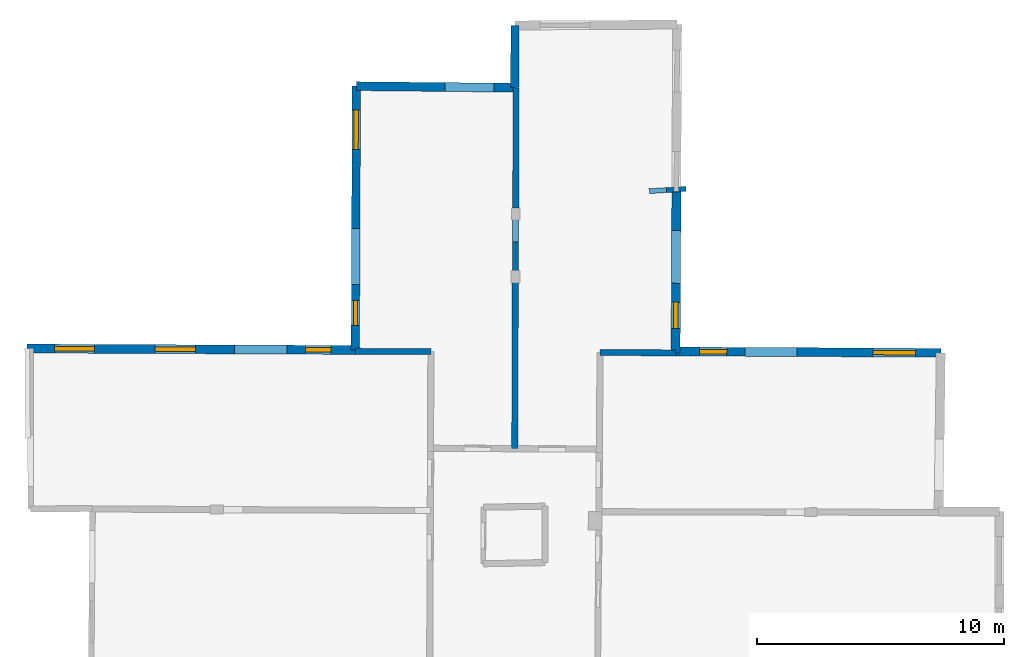
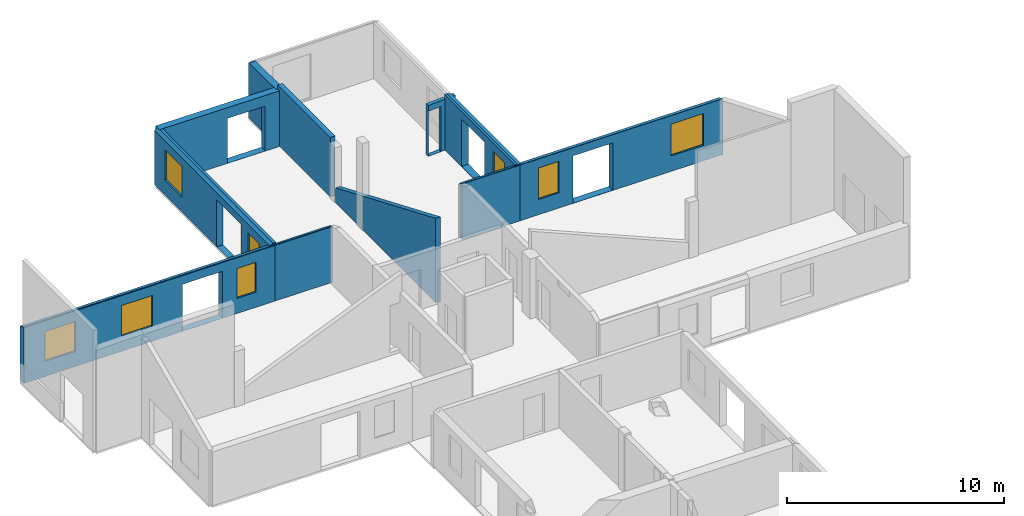
# One storey, part 8 of 10: 11 walls, 8 windows, 14 openings.
"""IFC2X3 building model written with IfcOpenShell, lengths in metres."""

from ifc_helpers import new_model, entity, si_unit, converted_unit, derived_unit, direction, frame, frame_2d, origin, origin_2d_with_axis, place, context, subcontext, project, spatial, polyline, rectangle, outline, extrude, clip, halfspace, source, transform, mapped, material, layer, layer_set, layer_usage, type_object, type_shapes, element, fill, save


model = new_model("IFC2X3")

# Units and contexts
model_context = context("Model", 3, precision=1e-05, world=origin(), true_north=direction((0.0, 1.0)))
body_context = subcontext(model_context, "Body", "Model", "MODEL_VIEW")
ifc_project = project(units=[si_unit("LENGTHUNIT", "METRE"), si_unit("AREAUNIT", "SQUARE_METRE"), si_unit("VOLUMEUNIT", "CUBIC_METRE"), converted_unit("PLANEANGLEUNIT", "DEGREE", entity("IfcRatioMeasure", 0.0174532925199433), si_unit("PLANEANGLEUNIT", "RADIAN"), dimensions=[0, 0, 0, 0, 0, 0, 0]), si_unit("MASSUNIT", "GRAM", prefix="KILO"), derived_unit("MASSDENSITYUNIT", [(si_unit("MASSUNIT", "GRAM", prefix="KILO"), 1), (si_unit("LENGTHUNIT", "METRE"), -3)]), derived_unit("MOMENTOFINERTIAUNIT", [(si_unit("LENGTHUNIT", "METRE"), 4)]), si_unit("TIMEUNIT", "SECOND"), si_unit("FREQUENCYUNIT", "HERTZ"), si_unit("THERMODYNAMICTEMPERATUREUNIT", "DEGREE_CELSIUS"), derived_unit("THERMALTRANSMITTANCEUNIT", [(si_unit("MASSUNIT", "GRAM", prefix="KILO"), 1), (si_unit("THERMODYNAMICTEMPERATUREUNIT", "KELVIN"), -1), (si_unit("TIMEUNIT", "SECOND"), -3)]), derived_unit("VOLUMETRICFLOWRATEUNIT", [(si_unit("LENGTHUNIT", "METRE"), 3), (si_unit("TIMEUNIT", "SECOND"), -1)]), si_unit("ELECTRICCURRENTUNIT", "AMPERE"), si_unit("ELECTRICVOLTAGEUNIT", "VOLT"), si_unit("POWERUNIT", "WATT"), si_unit("FORCEUNIT", "NEWTON", prefix="KILO"), si_unit("ILLUMINANCEUNIT", "LUX"), si_unit("LUMINOUSFLUXUNIT", "LUMEN"), si_unit("LUMINOUSINTENSITYUNIT", "CANDELA"), derived_unit("USERDEFINED", [(si_unit("MASSUNIT", "GRAM", prefix="KILO"), -1), (si_unit("LENGTHUNIT", "METRE"), -2), (si_unit("TIMEUNIT", "SECOND"), 3), (si_unit("LUMINOUSFLUXUNIT", "LUMEN"), 1)]), derived_unit("LINEARVELOCITYUNIT", [(si_unit("LENGTHUNIT", "METRE"), 1), (si_unit("TIMEUNIT", "SECOND"), -1)]), si_unit("PRESSUREUNIT", "PASCAL"), derived_unit("USERDEFINED", [(si_unit("LENGTHUNIT", "METRE"), -2), (si_unit("MASSUNIT", "GRAM", prefix="KILO"), 1), (si_unit("TIMEUNIT", "SECOND"), -2)]), derived_unit("LINEARFORCEUNIT", [(si_unit("MASSUNIT", "GRAM", prefix="KILO"), 1), (si_unit("LENGTHUNIT", "METRE"), 1), (si_unit("TIMEUNIT", "SECOND"), -2), (si_unit("LENGTHUNIT", "METRE"), -1)]), derived_unit("PLANARFORCEUNIT", [(si_unit("MASSUNIT", "GRAM", prefix="KILO"), 1), (si_unit("LENGTHUNIT", "METRE"), 1), (si_unit("TIMEUNIT", "SECOND"), -2), (si_unit("LENGTHUNIT", "METRE"), -2)])], contexts=[model_context])

# Site, building, storey
placement = place(None, origin())
site = spatial("IfcSite", under=ifc_project, at=placement, CompositionType="ELEMENT")
building = spatial("IfcBuilding", under=site, at=placement, CompositionType="ELEMENT")
storey_placement = place(placement, frame((0.0, 0.0, 15.2695512771606)))
storey = spatial("IfcBuildingStorey", under=building, at=storey_placement, Name="Level 6", CompositionType="ELEMENT", Elevation=15.2695512771606)

# Walls
ifc_material_1 = material(Name="Default wall")
ifc_layer_1 = layer(ifc_material_1, 0.25)
ifc_layer_set_1 = layer_set([ifc_layer_1], Name="wall_thickness_0.2500")
ifc_layer_usage_1 = layer_usage(ifc_layer_set_1, "AXIS2", "POSITIVE", -0.125)
wall_type_1 = type_object("IfcWallType", Name="wall_thickness_0.2500", PredefinedType="STANDARD", material=ifc_layer_set_1)
wall_1_placement = place(storey_placement, frame((-0.0808554602678225, 64.1063221067863, 0.0), z_axis=(0.0, 0.0, 1.0), x_axis=(0.999990908040432, -0.00426425098611989, 0.0)))
element("IfcWallStandardCase", 1, at=wall_1_placement, inside=storey, type_object=wall_type_1, material=ifc_layer_usage_1, Name="Wall:138", ObjectType="Wall", context=body_context, shape_type="Clipping", body=[
    clip(clip(extrude(outline(polyline([(3.06302876636839, -0.125), (3.06302876636839, 0.125), (0.0, 0.125), (0.0, -0.125), (3.06302876636839, -0.125)])), origin(), (0.0, 0.0, 1.0), 3.13044834136963), halfspace(frame((24.7355284661526, -6.49833158174328, 5.8221630359936), z_axis=(0.000812463095571987, 0.389454338634816, 0.921045415830423), x_axis=(-0.9999921605604, 0.0038858368837004, -0.000760979274747706)), False)), halfspace(frame((-1.23198617245779, 11.7323344706353, 2.60439273833051), z_axis=(-0.389900694771558, -0.000248207050535478, 0.920856876289642), x_axis=(0.920854588534137, -0.00162025768147186, 0.389902810378011)), False)),
])
wall_2_placement = place(storey_placement, frame((6.41512934361092, 69.4461332262615, 0.0), z_axis=(0.0, 0.0, 1.0), x_axis=(-0.00356605764891952, -0.999993641596208, 0.0)))
element("IfcWallStandardCase", 2, at=wall_2_placement, inside=storey, type_object=wall_type_1, material=ifc_layer_usage_1, Name="Wall:178", ObjectType="Wall", context=body_context, shape_type="Clipping", body=[
    clip(clip(extrude(outline(polyline([(9.29028505404974, -0.125), (9.29028505404974, 0.125), (0.0, 0.125), (0.0, -0.125), (9.29028505404974, -0.125)])), origin(), (0.0, 0.0, 1.0), 4.81944942474365), halfspace(frame((11.8785425334112, 18.2540838852891, 5.8221630359936), z_axis=(-0.389453676448308, 0.00108437938938624, 0.921045415830423), x_axis=(-0.00458402910890031, -0.999989203735556, -0.000760979274747706)), False)), halfspace(frame((-7.81326302486375, 6.37357314138311, 3.16730048752112), z_axis=(0.000511257317719443, 0.390499788056373, 0.920602875372374), x_axis=(0.672691778390289, -0.681309327540274, 0.288623234499112)), False)),
])
wall_3_placement = place(storey_placement, frame((6.43514733803296, 74.7923226373279, 0.0), z_axis=(0.0, 0.0, 1.0), x_axis=(-0.00260539055966853, -0.999996605964256, 0.0)))
element("IfcWallStandardCase", 3, at=wall_3_placement, inside=storey, type_object=wall_type_1, material=ifc_layer_usage_1, Name="Wall:204", ObjectType="Wall", context=body_context, shape_type="Clipping", body=[
    clip(extrude(outline(polyline([(4.86740238439549, -0.125), (4.86740238439549, 0.125), (0.0, 0.125), (0.0, -0.125), (4.86740238439549, -0.125)])), origin(), (0.0, 0.0, 1.0), 3.35544872283936), halfspace(frame((-3.7448441152025, 7.1505104693742, 2.58209439152611), z_axis=(-0.395636086504366, -0.00118573760532207, 0.918406598997329), x_axis=(0.00299703127652057, -0.999995508891679, 0.0)), False)),
])
wall_4_placement = place(storey_placement, frame((9.84309958674445, 64.0643808344133, 0.0), z_axis=(0.0, 0.0, 1.0), x_axis=(0.999967931691789, -0.00800846976933339, 0.0)))
element("IfcWallStandardCase", 4, at=wall_4_placement, inside=storey, type_object=wall_type_1, material=ifc_layer_usage_1, Name="Wall:206", ObjectType="Wall", context=body_context, shape_type="Clipping", body=[
    clip(clip(extrude(outline(polyline([(3.06091492319471, -0.125), (3.06091492319471, 0.125), (0.0, 0.125), (0.0, -0.125), (3.06091492319471, -0.125)])), origin(), (0.0, 0.0, 1.0), 3.13044834136963), halfspace(frame((14.8357139764424, -6.44320498425277, 5.8221630359936), z_axis=(-0.000645769749213463, 0.389454650709418, 0.921045415830423), x_axis=(-0.999999700436137, 0.000141556279795569, -0.000760979274747706)), False)), halfspace(frame((2.86784010269266, 13.1956273797904, 3.16730048752112), z_axis=(0.390498205913823, 0.00122353349064998, 0.920602875372374), x_axis=(-0.678314187703908, -0.675711840407476, 0.288623234499112)), False)),
])
ifc_layer_2 = layer(ifc_material_1, 0.340000003576279)
ifc_layer_set_2 = layer_set([ifc_layer_2], Name="wall_thickness_0.3400")
ifc_layer_usage_2 = layer_usage(ifc_layer_set_2, "AXIS2", "POSITIVE", -0.170000001788139)
wall_type_2 = type_object("IfcWallType", Name="wall_thickness_0.3400", PredefinedType="STANDARD", material=ifc_layer_set_2)
wall_5_placement = place(storey_placement, frame((6.39242875829822, 77.3210819114695, 0.0), z_axis=(0.0, 0.0, 1.0), x_axis=(-0.00183319546638739, -0.999998319695779, 0.0)))
element("IfcWallStandardCase", 5, at=wall_5_placement, inside=storey, type_object=wall_type_2, material=ifc_layer_usage_2, Name="Wall:179", ObjectType="Wall", context=body_context, shape_type="Clipping", body=[
    clip(extrude(outline(polyline([(2.52829404322503, -0.170000001788139), (2.52829404322503, 0.170000001788139), (0.0, 0.170000001788139), (0.0, -0.170000001788139), (2.52829404322503, -0.170000001788139)])), origin(), (0.0, 0.0, 1.0), 3.13044834136963), halfspace(frame((-1.21064468286421, 7.20075431263983, 2.58209439152611), z_axis=(-0.395636884170749, -0.000880228277492343, 0.918406598997329), x_axis=(0.00222483691363024, -0.999997525047291, 0.0)), False)),
])

# Wall, openings, windows
wall_6_placement = place(storey_placement, frame((-0.0391533251246667, 74.8569674091164, 0.0), z_axis=(0.0, 0.0, 1.0), x_axis=(-0.00387897058987082, -0.999992476765282, 0.0)))
wall_6 = element("IfcWallStandardCase", 6, at=wall_6_placement, inside=storey, type_object=wall_type_2, material=ifc_layer_usage_2, Name="Wall:219", ObjectType="Wall", context=body_context, shape_type="Clipping", body=[
    clip(extrude(outline(polyline([(10.6957439187404, -0.170000001788139), (10.6957439187404, 0.170000001788139), (0.0, 0.170000001788139), (0.0, -0.170000001788139), (10.6957439187404, -0.170000001788139)])), origin(), (0.0, 0.0, 1.0), 3.13044834136963), halfspace(frame((-0.982082079829738, -1.22746618961734, 2.60439273833051), z_axis=(9.79846955219276e-05, -0.389900761462559, 0.920856876289642), x_axis=(0.00197504771625913, 0.920853895928039, 0.389902810378011)), False)),
])
opening_1_placement = place(wall_6_placement, frame((5.77383189076389, -0.170000001788139, 0.00844955444335938)))
element("IfcOpeningElement", 7, at=opening_1_placement, cuts=wall_6, Name="Opening : 2260 x 2635 : 196", ObjectType="Opening", context=body_context, shape_type="SweptSolid", body=[
    extrude(rectangle(XDim=2.26, YDim=2.635, at=frame_2d((1.3175, 1.13), x_axis=(0.0, 1.0))), frame((0.0, 0.0, 0.0), z_axis=(0.0, 1.0, 0.0), x_axis=(0.0, 0.0, 1.0)), (0.0, 0.0, 1.0), 0.340000003576279),
])
opening_2_placement = place(wall_6_placement, frame((0.966201422497656, -0.170000001788139, 0.855448722839355)))
opening_2 = element("IfcOpeningElement", 8, at=opening_2_placement, cuts=wall_6, Name="Opening : 1595 x 1705 : 197", ObjectType="Opening", context=body_context, shape_type="SweptSolid", body=[
    extrude(rectangle(XDim=1.595, YDim=1.705, at=frame_2d((0.8525, 0.7975), x_axis=(0.0, 1.0))), frame((0.0, 0.0, 0.0), z_axis=(0.0, 1.0, 0.0), x_axis=(0.0, 0.0, 1.0)), (0.0, 0.0, 1.0), 0.340000003576279),
])
opening_3_placement = place(wall_6_placement, frame((8.69119697843685, -0.170000001788139, 0.84544849395752)))
opening_3 = element("IfcOpeningElement", 9, at=opening_3_placement, cuts=wall_6, Name="Opening : 1005 x 1725 : 198", ObjectType="Opening", context=body_context, shape_type="SweptSolid", body=[
    extrude(rectangle(XDim=1.005, YDim=1.725, at=frame_2d((0.8625, 0.5025), x_axis=(0.0, 1.0))), frame((0.0, 0.0, 0.0), z_axis=(0.0, 1.0, 0.0), x_axis=(0.0, 0.0, 1.0)), (0.0, 0.0, 1.0), 0.340000003576279),
])
ifc_material_2 = material(Name="Window Default")
window_style_1 = type_object("IfcWindowStyle", Name="Window : 1595 x 1705mm", ConstructionType="NOTDEFINED", OperationType="NOTDEFINED", ParameterTakesPrecedence=False, Sizeable=False, material=ifc_material_2)
shared_shape_1 = source(origin(), body_context, "Body", "SweptSolid", [
    extrude(rectangle(XDim=0.170000001788139, YDim=1.595, at=origin_2d_with_axis()), frame((0.7975, 0.170000001788139, 0.0), z_axis=(0.0, 0.0, 1.0), x_axis=(0.0, 1.0, 0.0)), (0.0, 0.0, 1.0), 1.705),
])
type_shapes(window_style_1, [shared_shape_1])
window_1_placement = place(opening_2_placement, origin())
window_1 = element("IfcWindow", 10, at=window_1_placement, inside=storey, type_object=window_style_1, Name="Window : 1595 x 1705mm : 106", ObjectType="Window : 1595 x 1705mm", OverallHeight=1.705, OverallWidth=1.595, context=body_context, shape_type="MappedRepresentation", body=[
    mapped(shared_shape_1, transform((0.0, 0.0, 0.0), scale=1.0)),
])
fill(opening_2, window_1)
window_style_2 = type_object("IfcWindowStyle", Name="Window : 1005 x 1725mm", ConstructionType="NOTDEFINED", OperationType="NOTDEFINED", ParameterTakesPrecedence=False, Sizeable=False, material=ifc_material_2)
shared_shape_2 = source(origin(), body_context, "Body", "SweptSolid", [
    extrude(rectangle(XDim=0.170000001788139, YDim=1.005, at=origin_2d_with_axis()), frame((0.5025, 0.170000001788139, 0.0), z_axis=(0.0, 0.0, 1.0), x_axis=(0.0, 1.0, 0.0)), (0.0, 0.0, 1.0), 1.725),
])
type_shapes(window_style_2, [shared_shape_2])
window_2_placement = place(opening_3_placement, origin())
window_2 = element("IfcWindow", 11, at=window_2_placement, inside=storey, type_object=window_style_2, Name="Window : 1005 x 1725mm : 107", ObjectType="Window : 1005 x 1725mm", OverallHeight=1.725, OverallWidth=1.005, context=body_context, shape_type="MappedRepresentation", body=[
    mapped(shared_shape_2, transform((0.0, 0.0, 0.0), scale=1.0)),
])
fill(opening_3, window_2)

# Wall, openings, window
ifc_layer_3 = layer(ifc_material_1, 0.370000004768372)
ifc_layer_set_3 = layer_set([ifc_layer_3], Name="wall_thickness_0.3700")
ifc_layer_usage_3 = layer_usage(ifc_layer_set_3, "AXIS2", "POSITIVE", -0.185000002384186)
wall_type_3 = type_object("IfcWallType", Name="wall_thickness_0.3700", PredefinedType="STANDARD", material=ifc_layer_set_3)
wall_7_placement = place(storey_placement, frame((12.9364584347764, 70.5787633835031, 0.0), z_axis=(0.0, 0.0, 1.0), x_axis=(-0.00497650960816691, -0.999987617099392, 0.0)))
wall_7 = element("IfcWallStandardCase", 12, at=wall_7_placement, inside=storey, type_object=wall_type_3, material=ifc_layer_usage_3, Name="Wall:199", ObjectType="Wall", context=body_context, shape_type="Clipping", body=[
    clip(extrude(outline(polyline([(6.53897562480555, -0.185000002384186), (6.53897562480555, 0.185000002384186), (0.0, 0.185000002384186), (0.0, -0.185000002384186), (6.53897562480555, -0.185000002384186)])), origin(), (0.0, 0.0, 1.0), 3.13044834136963), halfspace(frame((-6.65717536258581, -0.153065321708945, 3.16730048752112), z_axis=(-3.95292692730281e-05, 0.390500120734365, 0.920602875372374), x_axis=(0.673652071862865, -0.680359841982271, 0.288623234499112)), False)),
])
opening_4_placement = place(wall_7_placement, frame((1.57315487721787, -0.185000002384186, 0.0324487686157227)))
element("IfcOpeningElement", 13, at=opening_4_placement, cuts=wall_7, Name="Opening : 2140 x 2640 : 178", ObjectType="Opening", context=body_context, shape_type="SweptSolid", body=[
    extrude(rectangle(XDim=2.14, YDim=2.64, at=frame_2d((1.32, 1.07), x_axis=(0.0, 1.0))), frame((0.0, 0.0, 0.0), z_axis=(0.0, 1.0, 0.0), x_axis=(0.0, 0.0, 1.0)), (0.0, 0.0, 1.0), 0.370000004768372),
])
opening_5_placement = place(wall_7_placement, frame((4.4831487967861, -0.185000002384186, 0.867447853088379)))
opening_5 = element("IfcOpeningElement", 14, at=opening_5_placement, cuts=wall_7, Name="Opening : 1060 x 1775 : 179", ObjectType="Opening", context=body_context, shape_type="SweptSolid", body=[
    extrude(rectangle(XDim=1.06, YDim=1.775, at=frame_2d((0.8875, 0.53), x_axis=(0.0, 1.0))), frame((0.0, 0.0, 0.0), z_axis=(0.0, 1.0, 0.0), x_axis=(0.0, 0.0, 1.0)), (0.0, 0.0, 1.0), 0.370000004768372),
])
window_style_3 = type_object("IfcWindowStyle", Name="Window : 1060 x 1775mm", ConstructionType="NOTDEFINED", OperationType="NOTDEFINED", ParameterTakesPrecedence=False, Sizeable=False, material=ifc_material_2)
shared_shape_3 = source(origin(), body_context, "Body", "SweptSolid", [
    extrude(rectangle(XDim=0.185000002384186, YDim=1.06, at=origin_2d_with_axis()), frame((0.53, 0.185000002384186, 0.0), z_axis=(0.0, 0.0, 1.0), x_axis=(0.0, 1.0, 0.0)), (0.0, 0.0, 1.0), 1.775),
])
type_shapes(window_style_3, [shared_shape_3])
window_3_placement = place(opening_5_placement, origin())
window_3 = element("IfcWindow", 15, at=window_3_placement, inside=storey, type_object=window_style_3, Name="Window : 1060 x 1775mm : 98", ObjectType="Window : 1060 x 1775mm", OverallHeight=1.775, OverallWidth=1.06, context=body_context, shape_type="MappedRepresentation", body=[
    mapped(shared_shape_3, transform((0.0, 0.0, 0.0), scale=1.0)),
])
fill(opening_5, window_3)

# Wall, opening
ifc_layer_4 = layer(ifc_material_1, 0.200000002980232)
ifc_layer_set_4 = layer_set([ifc_layer_4], Name="wall_thickness_0.2000")
ifc_layer_usage_4 = layer_usage(ifc_layer_set_4, "AXIS2", "POSITIVE", -0.100000001490116)
wall_type_4 = type_object("IfcWallType", Name="wall_thickness_0.2000", PredefinedType="STANDARD", material=ifc_layer_set_4)
wall_8_placement = place(storey_placement, frame((11.8404997968382, 70.6001744071799, 0.0), z_axis=(0.0, 0.0, 1.0), x_axis=(0.998158158960868, 0.0606653912857232, 0.0)))
wall_8 = element("IfcWallStandardCase", 16, at=wall_8_placement, inside=storey, type_object=wall_type_4, material=ifc_layer_usage_4, Name="Wall:129", ObjectType="Wall", context=body_context, shape_type="Clipping", body=[
    clip(extrude(outline(polyline([(1.48927235321937, -0.100000001490116), (1.48927235321937, 0.100000001490116), (0.0, 0.100000001490116), (0.0, -0.100000001490116), (1.48927235321937, -0.100000001490116)])), origin(), (0.0, 0.0, 1.0), 2.86044979095459), halfspace(frame((1.37682947626478, 6.56500943970926, 3.16730048752112), z_axis=(0.389660756623232, -0.0255898535347038, 0.920602875372374), x_axis=(-0.723106037889493, -0.627546242499332, 0.288623234499112)), False)),
])
opening_6_placement = place(wall_8_placement, frame((0.00499976340376304, -0.100000001490116, 0.00544929504394531)))
element("IfcOpeningElement", 17, at=opening_6_placement, cuts=wall_8, Name="Opening : 695 x 2530 : 118", ObjectType="Opening", context=body_context, shape_type="SweptSolid", body=[
    extrude(rectangle(XDim=0.695, YDim=2.53, at=frame_2d((1.265, 0.3475), x_axis=(0.0, 1.0))), frame((0.0, 0.0, 0.0), z_axis=(0.0, 1.0, 0.0), x_axis=(0.0, 0.0, 1.0)), (0.0, 0.0, 1.0), 0.200000002980232),
])

# Wall, openings, windows
ifc_layer_5 = layer(ifc_material_1, 0.360000014305115)
ifc_layer_set_5 = layer_set([ifc_layer_5], Name="wall_thickness_0.3600")
ifc_layer_usage_5 = layer_usage(ifc_layer_set_5, "AXIS2", "POSITIVE", -0.180000007152557)
wall_type_5 = type_object("IfcWallType", Name="wall_thickness_0.3600", PredefinedType="STANDARD", material=ifc_layer_set_5)
wall_9_placement = place(storey_placement, frame((-13.3852670753108, 64.2180003874397, 0.0), z_axis=(0.0, 0.0, 1.0), x_axis=(0.999990922317803, -0.00426090154655913, 0.0)))
wall_9 = element("IfcWallStandardCase", 18, at=wall_9_placement, inside=storey, type_object=wall_type_5, material=ifc_layer_usage_5, Name="Wall:137", ObjectType="Wall", context=body_context, shape_type="Clipping", body=[
    clip(extrude(outline(polyline([(13.3047467642694, -0.180000007152557), (13.3047467642694, 0.180000007152557), (0.0, 0.180000007152557), (0.0, -0.180000007152557), (13.3047467642694, -0.180000007152557)])), origin(), (0.0, 0.0, 1.0), 3.13044834136963), halfspace(frame((38.0402733920286, -6.55340291146397, 5.8221630359936), z_axis=(0.000813767561187197, 0.38945433591131, 0.921045415830423), x_axis=(-0.999992147539296, 0.00388918632741073, -0.000760979274747706)), False)),
])
opening_7_placement = place(wall_9_placement, frame((8.41051156879959, -0.180000007152557, 0.00544929504394531)))
element("IfcOpeningElement", 19, at=opening_7_placement, cuts=wall_9, Name="Opening : 2120 x 2640 : 125", ObjectType="Opening", context=body_context, shape_type="SweptSolid", body=[
    extrude(rectangle(XDim=2.12, YDim=2.64, at=frame_2d((1.32, 1.06), x_axis=(0.0, 1.0))), frame((0.0, 0.0, 0.0), z_axis=(0.0, 1.0, 0.0), x_axis=(0.0, 0.0, 1.0)), (0.0, 0.0, 1.0), 0.360000014305115),
])
opening_8_placement = place(wall_9_placement, frame((11.2840837826646, -0.180000007152557, 0.850449562072754)))
opening_8 = element("IfcOpeningElement", 20, at=opening_8_placement, cuts=wall_9, Name="Opening : 1030 x 1680 : 126", ObjectType="Opening", context=body_context, shape_type="SweptSolid", body=[
    extrude(rectangle(XDim=1.03, YDim=1.68, at=frame_2d((0.84, 0.515), x_axis=(0.0, 1.0))), frame((0.0, 0.0, 0.0), z_axis=(0.0, 1.0, 0.0), x_axis=(0.0, 0.0, 1.0)), (0.0, 0.0, 1.0), 0.360000014305115),
])
opening_9_placement = place(wall_9_placement, frame((5.17408398559702, -0.180000007152557, 0.850449562072754)))
opening_9 = element("IfcOpeningElement", 21, at=opening_9_placement, cuts=wall_9, Name="Opening : 1640 x 1725 : 127", ObjectType="Opening", context=body_context, shape_type="SweptSolid", body=[
    extrude(rectangle(XDim=1.64, YDim=1.725, at=frame_2d((0.8625, 0.82), x_axis=(0.0, 1.0))), frame((0.0, 0.0, 0.0), z_axis=(0.0, 1.0, 0.0), x_axis=(0.0, 0.0, 1.0)), (0.0, 0.0, 1.0), 0.360000014305115),
])
opening_10_placement = place(wall_9_placement, frame((1.11408293230047, -0.180000007152557, 0.850449562072754)))
opening_10 = element("IfcOpeningElement", 22, at=opening_10_placement, cuts=wall_9, Name="Opening : 1610 x 1680 : 128", ObjectType="Opening", context=body_context, shape_type="SweptSolid", body=[
    extrude(rectangle(XDim=1.61, YDim=1.68, at=frame_2d((0.84, 0.805), x_axis=(0.0, 1.0))), frame((0.0, 0.0, 0.0), z_axis=(0.0, 1.0, 0.0), x_axis=(0.0, 0.0, 1.0)), (0.0, 0.0, 1.0), 0.360000014305115),
])
window_style_4 = type_object("IfcWindowStyle", Name="Window : 1030 x 1680mm", ConstructionType="NOTDEFINED", OperationType="NOTDEFINED", ParameterTakesPrecedence=False, Sizeable=False, material=ifc_material_2)
shared_shape_4 = source(origin(), body_context, "Body", "SweptSolid", [
    extrude(rectangle(XDim=0.180000007152557, YDim=1.03, at=origin_2d_with_axis()), frame((0.515, 0.180000007152557, 0.0), z_axis=(0.0, 0.0, 1.0), x_axis=(0.0, 1.0, 0.0)), (0.0, 0.0, 1.0), 1.68),
])
type_shapes(window_style_4, [shared_shape_4])
window_4_placement = place(opening_8_placement, origin())
window_4 = element("IfcWindow", 23, at=window_4_placement, inside=storey, type_object=window_style_4, Name="Window : 1030 x 1680mm : 71", ObjectType="Window : 1030 x 1680mm", OverallHeight=1.68, OverallWidth=1.03, context=body_context, shape_type="MappedRepresentation", body=[
    mapped(shared_shape_4, transform((0.0, 0.0, 0.0), scale=1.0)),
])
fill(opening_8, window_4)
window_style_5 = type_object("IfcWindowStyle", Name="Window : 1640 x 1725mm", ConstructionType="NOTDEFINED", OperationType="NOTDEFINED", ParameterTakesPrecedence=False, Sizeable=False, material=ifc_material_2)
shared_shape_5 = source(origin(), body_context, "Body", "SweptSolid", [
    extrude(rectangle(XDim=0.180000007152557, YDim=1.64, at=origin_2d_with_axis()), frame((0.82, 0.180000007152557, 0.0), z_axis=(0.0, 0.0, 1.0), x_axis=(0.0, 1.0, 0.0)), (0.0, 0.0, 1.0), 1.725),
])
type_shapes(window_style_5, [shared_shape_5])
window_5_placement = place(opening_9_placement, origin())
window_5 = element("IfcWindow", 24, at=window_5_placement, inside=storey, type_object=window_style_5, Name="Window : 1640 x 1725mm : 72", ObjectType="Window : 1640 x 1725mm", OverallHeight=1.725, OverallWidth=1.64, context=body_context, shape_type="MappedRepresentation", body=[
    mapped(shared_shape_5, transform((0.0, 0.0, 0.0), scale=1.0)),
])
fill(opening_9, window_5)
window_style_6 = type_object("IfcWindowStyle", Name="Window : 1610 x 1680mm", ConstructionType="NOTDEFINED", OperationType="NOTDEFINED", ParameterTakesPrecedence=False, Sizeable=False, material=ifc_material_2)
shared_shape_6 = source(origin(), body_context, "Body", "SweptSolid", [
    extrude(rectangle(XDim=0.180000007152557, YDim=1.61, at=origin_2d_with_axis()), frame((0.805, 0.180000007152557, 0.0), z_axis=(0.0, 0.0, 1.0), x_axis=(0.0, 1.0, 0.0)), (0.0, 0.0, 1.0), 1.68),
])
type_shapes(window_style_6, [shared_shape_6])
window_6_placement = place(opening_10_placement, origin())
window_6 = element("IfcWindow", 25, at=window_6_placement, inside=storey, type_object=window_style_6, Name="Window : 1610 x 1680mm : 73", ObjectType="Window : 1610 x 1680mm", OverallHeight=1.68, OverallWidth=1.61, context=body_context, shape_type="MappedRepresentation", body=[
    mapped(shared_shape_6, transform((0.0, 0.0, 0.0), scale=1.0)),
])
fill(opening_10, window_6)

# Wall, opening
wall_10_placement = place(storey_placement, frame((-0.0391534251061658, 74.8569472173081, 0.0), z_axis=(0.0, 0.0, 1.0), x_axis=(0.999950192635654, -0.00998059356542757, 0.0)))
wall_10 = element("IfcWallStandardCase", 26, at=wall_10_placement, inside=storey, type_object=wall_type_5, material=ifc_layer_usage_5, Name="Wall:149", ObjectType="Wall", context=body_context, shape_type="Clipping", body=[
    clip(extrude(outline(polyline([(6.42726795738445, -0.180000007152557), (6.42726795738445, 0.180000007152557), (0.0, 0.180000007152557), (0.0, -0.180000007152557), (6.42726795738445, -0.180000007152557)])), origin(), (0.0, 0.0, 1.0), 3.13044834136963), halfspace(frame((13.5973199328698, 3.79747541868462, 2.58209439152611), z_axis=(-0.00410363974892753, 0.395616580869622, 0.918406598997329), x_axis=(-0.999946207125567, -0.0103722155392417, 0.0)), False)),
])
opening_11_placement = place(wall_10_placement, frame((3.5968028977113, -0.180000007152557, 0.00544929504394531)))
element("IfcOpeningElement", 27, at=opening_11_placement, cuts=wall_10, Name="Opening : 1990 x 2525 : 144", ObjectType="Opening", context=body_context, shape_type="SweptSolid", body=[
    extrude(rectangle(XDim=1.99, YDim=2.525, at=frame_2d((1.2625, 0.995), x_axis=(0.0, 1.0))), frame((0.0, 0.0, 0.0), z_axis=(0.0, 1.0, 0.0), x_axis=(0.0, 0.0, 1.0)), (0.0, 0.0, 1.0), 0.360000014305115),
])

# Wall, openings, windows
wall_11_placement = place(storey_placement, frame((12.904217884567, 64.1006289836884, 0.0), z_axis=(0.0, 0.0, 1.0), x_axis=(0.999986483674064, -0.00519927583238036, 0.0)))
wall_11 = element("IfcWallStandardCase", 28, at=wall_11_placement, inside=storey, type_object=wall_type_5, material=ifc_layer_usage_5, Name="Wall:202", ObjectType="Wall", context=body_context, shape_type="Clipping", body=[
    clip(extrude(outline(polyline([(10.7530750295669, -0.180000007152557), (10.7530750295669, 0.180000007152557), (0.0, 0.180000007152557), (0.0, -0.180000007152557), (10.7530750295669, -0.180000007152557)])), origin(), (0.0, 0.0, 1.0), 3.13044834136963), halfspace(frame((11.7566663875046, -6.53702008280756, 5.8221630359936), z_axis=(0.000448309220449676, 0.389454928068199, 0.921045415830423), x_axis=(-0.999995356812621, 0.00295080730351527, -0.000760979274747706)), False)),
])
opening_12_placement = place(wall_11_placement, frame((2.80914972003206, -0.180000007152557, 0.011448860168457)))
element("IfcOpeningElement", 29, at=opening_12_placement, cuts=wall_11, Name="Opening : 2110 x 2660 : 184", ObjectType="Opening", context=body_context, shape_type="SweptSolid", body=[
    extrude(rectangle(XDim=2.11, YDim=2.66, at=frame_2d((1.33, 1.055), x_axis=(0.0, 1.0))), frame((0.0, 0.0, 0.0), z_axis=(0.0, 1.0, 0.0), x_axis=(0.0, 0.0, 1.0)), (0.0, 0.0, 1.0), 0.360000014305115),
])
opening_13_placement = place(wall_11_placement, frame((7.99414963121245, -0.180000007152557, 0.87144947052002)))
opening_13 = element("IfcOpeningElement", 30, at=opening_13_placement, cuts=wall_11, Name="Opening : 1740 x 1785 : 185", ObjectType="Opening", context=body_context, shape_type="SweptSolid", body=[
    extrude(rectangle(XDim=1.74, YDim=1.785, at=frame_2d((0.8925, 0.87), x_axis=(0.0, 1.0))), frame((0.0, 0.0, 0.0), z_axis=(0.0, 1.0, 0.0), x_axis=(0.0, 0.0, 1.0)), (0.0, 0.0, 1.0), 0.360000014305115),
])
opening_14_placement = place(wall_11_placement, frame((0.974149675548865, -0.180000007152557, 0.856448173522949)))
opening_14 = element("IfcOpeningElement", 31, at=opening_14_placement, cuts=wall_11, Name="Opening : 1100 x 1770 : 186", ObjectType="Opening", context=body_context, shape_type="SweptSolid", body=[
    extrude(rectangle(XDim=1.1, YDim=1.77, at=frame_2d((0.885, 0.55), x_axis=(0.0, 1.0))), frame((0.0, 0.0, 0.0), z_axis=(0.0, 1.0, 0.0), x_axis=(0.0, 0.0, 1.0)), (0.0, 0.0, 1.0), 0.360000014305115),
])
window_style_7 = type_object("IfcWindowStyle", Name="Window : 1740 x 1785mm", ConstructionType="NOTDEFINED", OperationType="NOTDEFINED", ParameterTakesPrecedence=False, Sizeable=False, material=ifc_material_2)
shared_shape_7 = source(origin(), body_context, "Body", "SweptSolid", [
    extrude(rectangle(XDim=0.180000007152557, YDim=1.74, at=origin_2d_with_axis()), frame((0.87, 0.180000007152557, 0.0), z_axis=(0.0, 0.0, 1.0), x_axis=(0.0, 1.0, 0.0)), (0.0, 0.0, 1.0), 1.785),
])
type_shapes(window_style_7, [shared_shape_7])
window_7_placement = place(opening_13_placement, origin())
window_7 = element("IfcWindow", 32, at=window_7_placement, inside=storey, type_object=window_style_7, Name="Window : 1740 x 1785mm : 102", ObjectType="Window : 1740 x 1785mm", OverallHeight=1.785, OverallWidth=1.74, context=body_context, shape_type="MappedRepresentation", body=[
    mapped(shared_shape_7, transform((0.0, 0.0, 0.0), scale=1.0)),
])
fill(opening_13, window_7)
window_style_8 = type_object("IfcWindowStyle", Name="Window : 1100 x 1770mm", ConstructionType="NOTDEFINED", OperationType="NOTDEFINED", ParameterTakesPrecedence=False, Sizeable=False, material=ifc_material_2)
shared_shape_8 = source(origin(), body_context, "Body", "SweptSolid", [
    extrude(rectangle(XDim=0.180000007152557, YDim=1.1, at=origin_2d_with_axis()), frame((0.55, 0.180000007152557, 0.0), z_axis=(0.0, 0.0, 1.0), x_axis=(0.0, 1.0, 0.0)), (0.0, 0.0, 1.0), 1.77),
])
type_shapes(window_style_8, [shared_shape_8])
window_8_placement = place(opening_14_placement, origin())
window_8 = element("IfcWindow", 33, at=window_8_placement, inside=storey, type_object=window_style_8, Name="Window : 1100 x 1770mm : 103", ObjectType="Window : 1100 x 1770mm", OverallHeight=1.77, OverallWidth=1.1, context=body_context, shape_type="MappedRepresentation", body=[
    mapped(shared_shape_8, transform((0.0, 0.0, 0.0), scale=1.0)),
])
fill(opening_14, window_8)

save(model, "model.ifc")
